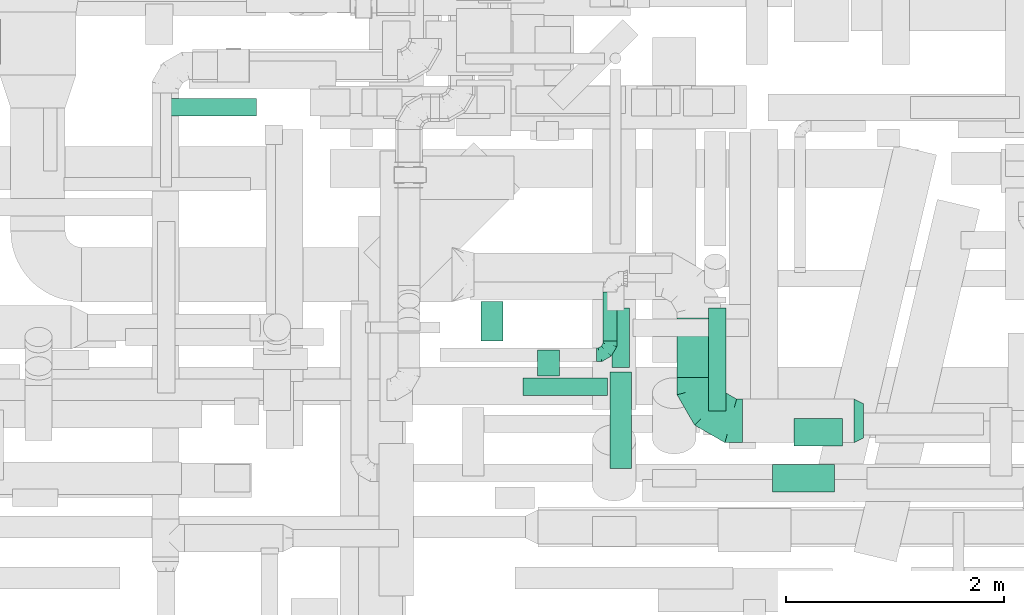
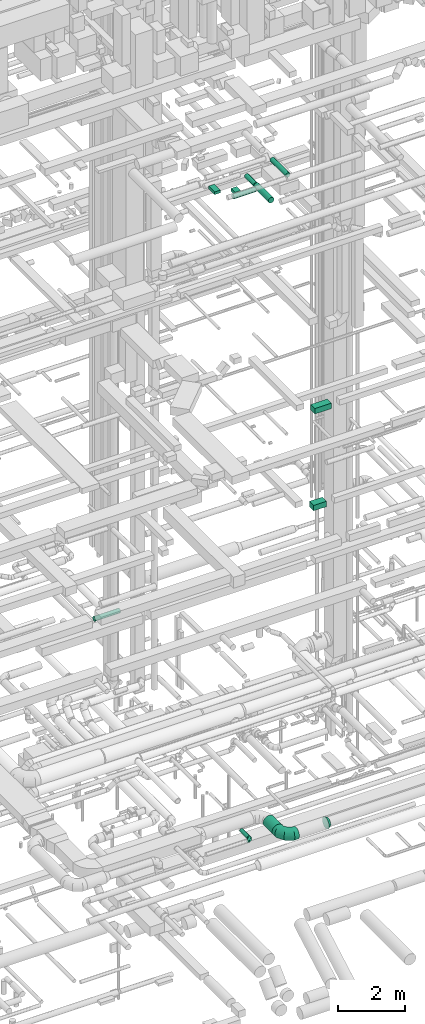
# One storey, part 164 of 337: 11 flow segments, 3 flow fittings.
"""IFC2X3 building model written with IfcOpenShell, lengths in millimetres."""

from ifc_helpers import new_model, entity, si_unit, converted_unit, derived_unit, direction, frame, origin, origin_2d_with_axis, place, context, subcontext, project, spatial, rectangle, circle, extrude, faceted_brep, source, transform, mapped, material, type_object, type_shapes, element, save


model = new_model("IFC2X3")

# Units and contexts
model_context = context("Model", 3, precision=0.01, world=origin(), true_north=direction((6.12303176911189e-17, 1.0)))
body_context = subcontext(model_context, "Body", "Model", "MODEL_VIEW")
ifc_project = project(units=[si_unit("LENGTHUNIT", "METRE", prefix="MILLI"), si_unit("AREAUNIT", "SQUARE_METRE"), si_unit("VOLUMEUNIT", "CUBIC_METRE"), converted_unit("PLANEANGLEUNIT", "DEGREE", entity("IfcRatioMeasure", 0.0174532925199433), si_unit("PLANEANGLEUNIT", "RADIAN"), dimensions=[0, 0, 0, 0, 0, 0, 0]), si_unit("MASSUNIT", "GRAM", prefix="KILO"), derived_unit("MASSDENSITYUNIT", [(si_unit("MASSUNIT", "GRAM", prefix="KILO"), 1), (si_unit("LENGTHUNIT", "METRE"), -3)]), derived_unit("MOMENTOFINERTIAUNIT", [(si_unit("LENGTHUNIT", "METRE"), 4)]), si_unit("TIMEUNIT", "SECOND"), si_unit("FREQUENCYUNIT", "HERTZ"), si_unit("THERMODYNAMICTEMPERATUREUNIT", "DEGREE_CELSIUS"), derived_unit("THERMALTRANSMITTANCEUNIT", [(si_unit("MASSUNIT", "GRAM", prefix="KILO"), 1), (si_unit("THERMODYNAMICTEMPERATUREUNIT", "KELVIN"), -1), (si_unit("TIMEUNIT", "SECOND"), -3)]), derived_unit("VOLUMETRICFLOWRATEUNIT", [(si_unit("LENGTHUNIT", "METRE"), 3), (si_unit("TIMEUNIT", "SECOND"), -1)]), derived_unit("MASSFLOWRATEUNIT", [(si_unit("MASSUNIT", "GRAM", prefix="KILO"), 1), (si_unit("TIMEUNIT", "SECOND"), -1)]), derived_unit("ROTATIONALFREQUENCYUNIT", [(si_unit("TIMEUNIT", "SECOND"), -1)]), si_unit("ELECTRICCURRENTUNIT", "AMPERE"), si_unit("ELECTRICVOLTAGEUNIT", "VOLT"), si_unit("POWERUNIT", "WATT"), si_unit("FORCEUNIT", "NEWTON", prefix="KILO"), si_unit("ILLUMINANCEUNIT", "LUX"), si_unit("LUMINOUSFLUXUNIT", "LUMEN"), si_unit("LUMINOUSINTENSITYUNIT", "CANDELA"), derived_unit("USERDEFINED", [(si_unit("MASSUNIT", "GRAM", prefix="KILO"), -1), (si_unit("LENGTHUNIT", "METRE"), -2), (si_unit("TIMEUNIT", "SECOND"), 3), (si_unit("LUMINOUSFLUXUNIT", "LUMEN"), 1)]), derived_unit("LINEARVELOCITYUNIT", [(si_unit("LENGTHUNIT", "METRE"), 1), (si_unit("TIMEUNIT", "SECOND"), -1)]), si_unit("PRESSUREUNIT", "PASCAL"), derived_unit("USERDEFINED", [(si_unit("LENGTHUNIT", "METRE"), -2), (si_unit("MASSUNIT", "GRAM", prefix="KILO"), 1), (si_unit("TIMEUNIT", "SECOND"), -2)]), derived_unit("LINEARFORCEUNIT", [(si_unit("MASSUNIT", "GRAM", prefix="KILO"), 1), (si_unit("LENGTHUNIT", "METRE"), 1), (si_unit("TIMEUNIT", "SECOND"), -2), (si_unit("LENGTHUNIT", "METRE"), -1)]), derived_unit("PLANARFORCEUNIT", [(si_unit("MASSUNIT", "GRAM", prefix="KILO"), 1), (si_unit("LENGTHUNIT", "METRE"), 1), (si_unit("TIMEUNIT", "SECOND"), -2), (si_unit("LENGTHUNIT", "METRE"), -2)])], contexts=[model_context])

# Site, building, storey
site_placement = place(None, origin())
site = spatial("IfcSite", under=ifc_project, at=site_placement, CompositionType="ELEMENT")
building_placement = place(site_placement, origin())
building = spatial("IfcBuilding", under=site, at=building_placement, CompositionType="ELEMENT")
storey_placement = place(building_placement, origin())
storey = spatial("IfcBuildingStorey", under=building, at=storey_placement, CompositionType="ELEMENT", Elevation=0.0)

# Flow segments
duct_segment_type_1 = type_object("IfcDuctSegmentType", PredefinedType="NOTDEFINED")
flow_segment_1_placement = place(storey_placement, frame((52915.22, 2152.06, 19075.0)))
element("IfcFlowSegment", 1, at=flow_segment_1_placement, inside=storey, type_object=duct_segment_type_1, context=body_context, shape_type="SweptSolid", body=[
    extrude(rectangle(XDim=570.000000000061, YDim=250.0, at=origin_2d_with_axis()), frame((285.0, 125.0, 0.0)), (0.0, 0.0, 1.0), 200.000000000002),
])
flow_segment_2_placement = place(storey_placement, frame((53116.01, 2575.44, 15200.0)))
element("IfcFlowSegment", 2, at=flow_segment_2_placement, inside=storey, type_object=duct_segment_type_1, context=body_context, shape_type="SweptSolid", body=[
    extrude(rectangle(XDim=445.00000000002, YDim=250.0, at=origin_2d_with_axis()), frame((222.5, 125.0, 0.0)), (0.0, 0.0, 1.0), 200.000000000002),
])
flow_segment_3_placement = place(storey_placement, frame((50242.89, 3538.11, 27200.0)))
element("IfcFlowSegment", 3, at=flow_segment_3_placement, inside=storey, type_object=duct_segment_type_1, context=body_context, shape_type="SweptSolid", body=[
    extrude(rectangle(XDim=360.627460668063, YDim=199.999999999998, at=origin_2d_with_axis()), frame((100.0, 180.31, 0.0), z_axis=(0.0, 0.0, 1.0), x_axis=(0.0, -1.0, 0.0)), (0.0, 0.0, 1.0), 100.000000000003),
])
flow_segment_4_placement = place(storey_placement, frame((50760.52, 3214.9, 27200.0)))
element("IfcFlowSegment", 4, at=flow_segment_4_placement, inside=storey, type_object=duct_segment_type_1, context=body_context, shape_type="SweptSolid", body=[
    extrude(rectangle(XDim=239.999999999976, YDim=199.999999999998, at=origin_2d_with_axis()), frame((100.0, 120.0, 0.0), z_axis=(0.0, 0.0, 1.0), x_axis=(0.0, 1.0, 0.0)), (0.0, 0.0, 1.0), 100.000000000003),
])
duct_segment_type_2 = type_object("IfcDuctSegmentType", PredefinedType="NOTDEFINED")
flow_segment_5_placement = place(storey_placement, frame((47301.3, 5598.95, 11318.4)))
element("IfcFlowSegment", 5, at=flow_segment_5_placement, inside=storey, type_object=duct_segment_type_2, context=body_context, shape_type="SweptSolid", body=[
    extrude(circle(Radius=80.0, at=origin_2d_with_axis()), frame((0.0, 81.6, 81.6), z_axis=(1.0, 0.0, 0.0), x_axis=(0.0, 1.0, 0.0)), (0.0, 0.0, 1.0), 880.000000000025),
])
flow_segment_6_placement = place(storey_placement, frame((52039.25, 3203.74, 3248.4)))
element("IfcFlowSegment", 6, at=flow_segment_6_placement, inside=storey, type_object=duct_segment_type_2, context=body_context, shape_type="SweptSolid", body=[
    extrude(circle(Radius=200.0, at=origin_2d_with_axis()), frame((201.6, 0.0, 201.6), z_axis=(0.0, 1.0, 0.0), x_axis=(-1.0, 0.0, 0.0)), (0.0, 0.0, 1.0), 542.500000000014),
])
flow_segment_7_placement = place(storey_placement, frame((52328.05, 2895.97, 27468.4)))
element("IfcFlowSegment", 7, at=flow_segment_7_placement, inside=storey, type_object=duct_segment_type_2, context=body_context, shape_type="SweptSolid", body=[
    extrude(circle(Radius=80.0, at=origin_2d_with_axis()), frame((81.6, 0.0, 81.6), z_axis=(0.0, 1.0, 0.0), x_axis=(-1.0, 0.0, 0.0)), (0.0, 0.0, 1.0), 942.141311520767),
])
flow_segment_8_placement = place(storey_placement, frame((51422.09, 2365.61, 27158.4)))
element("IfcFlowSegment", 8, at=flow_segment_8_placement, inside=storey, type_object=duct_segment_type_2, context=body_context, shape_type="SweptSolid", body=[
    extrude(circle(Radius=100.0, at=origin_2d_with_axis()), frame((101.6, 0.0, 101.6), z_axis=(0.0, 1.0, 0.0), x_axis=(1.0, 0.0, 0.0)), (0.0, 0.0, 1.0), 887.500000000023),
])
flow_segment_9_placement = place(storey_placement, frame((51442.09, 3293.11, 27178.4)))
element("IfcFlowSegment", 9, at=flow_segment_9_placement, inside=storey, type_object=duct_segment_type_2, context=body_context, shape_type="SweptSolid", body=[
    extrude(circle(Radius=80.0, at=origin_2d_with_axis()), frame((81.6, 0.0, 81.6), z_axis=(0.0, 1.0, 0.0), x_axis=(1.0, 0.0, 0.0)), (0.0, 0.0, 1.0), 544.999999999997),
])
flow_segment_10_placement = place(storey_placement, frame((50628.69, 3033.31, 27168.4)))
element("IfcFlowSegment", 10, at=flow_segment_10_placement, inside=storey, type_object=duct_segment_type_2, context=body_context, shape_type="SweptSolid", body=[
    extrude(circle(Radius=80.0, at=origin_2d_with_axis()), frame((0.0, 81.6, 81.6), z_axis=(1.0, 0.0, 0.0), x_axis=(0.0, 1.0, 0.0)), (0.0, 0.0, 1.0), 775.501256289328),
])
flow_segment_11_placement = place(storey_placement, frame((51360.9, 3535.29, 3185.9)))
element("IfcFlowSegment", 11, at=flow_segment_11_placement, inside=storey, type_object=duct_segment_type_2, context=body_context, shape_type="SweptSolid", body=[
    extrude(circle(Radius=62.5, at=origin_2d_with_axis()), frame((64.1, 0.0, 64.1), z_axis=(0.0, 1.0, 0.0), x_axis=(-1.0, 0.0, 0.0)), (0.0, 0.0, 1.0), 450.000000000008),
])

# Flow fittings
ifc_material = material()
duct_fitting_type_1 = type_object("IfcDuctFittingType", PredefinedType="NOTDEFINED", material=ifc_material)
shared_shape_1 = source(origin(), body_context, "Body", "Brep", [
    faceted_brep([(-125.0, 0.0, -62.5), (-125.0, -16.18, -60.37), (-125.0, -31.25, -54.13), (-125.0, -44.19, -44.19), (-125.0, -54.13, -31.25), (-125.0, -60.37, -16.18), (-125.0, -62.5, 0.0), (-125.0, -60.37, 16.18), (-125.0, -54.13, 31.25), (-125.0, -44.19, 44.19), (-125.0, -31.25, 54.13), (-125.0, -16.18, 60.37), (-125.0, 0.0, 62.5), (-125.0, 16.18, 60.37), (-125.0, 31.25, 54.13), (-125.0, 44.19, 44.19), (-125.0, 54.13, 31.25), (-125.0, 60.37, 16.18), (-125.0, 62.5, 0.0), (-125.0, 60.37, -16.18), (-125.0, 54.13, -31.25), (-125.0, 44.19, -44.19), (-125.0, 31.25, -54.13), (-125.0, 16.18, -60.37), (-95.84, 16.18, 60.37), (-99.88, 31.25, 54.13), (-91.51, 0.0, 62.5), (-103.35, 44.19, 44.19), (-107.68, 60.37, 16.18), (-108.25, 62.5, 0.0), (-106.01, 54.13, 31.25), (-106.01, 54.13, -31.25), (-103.35, 44.19, -44.19), (-107.68, 60.37, -16.18), (-95.84, 16.18, -60.37), (-91.51, 0.0, -62.5), (-99.88, 31.25, -54.13), (-87.17, -16.18, -60.37), (-83.13, -31.25, -54.13), (-79.66, -44.19, -44.19), (-77.0, -54.13, -31.25), (-75.33, -60.37, -16.18), (-74.76, -62.5, 0.0), (-75.33, -60.37, 16.18), (-77.0, -54.13, 31.25), (-79.66, -44.19, 44.19), (-83.13, -31.25, 54.13), (-87.17, -16.18, 60.37), (-45.34, 45.34, 60.37), (-56.37, 56.37, 54.13), (-33.49, 33.49, 62.5), (-65.85, 65.85, 44.19), (-73.12, 73.12, 31.25), (-77.69, 77.69, 16.18), (-79.25, 79.25, 0.0), (-77.69, 77.69, -16.18), (-73.12, 73.12, -31.25), (-65.85, 65.85, -44.19), (-45.34, 45.34, -60.37), (-33.49, 33.49, -62.5), (-56.37, 56.37, -54.13), (-21.65, 21.65, -60.37), (-10.62, 10.62, -54.13), (-1.14, 1.14, -44.19), (6.13, -6.13, -31.25), (10.7, -10.7, -16.18), (12.26, -12.26, 0.0), (10.7, -10.7, 16.18), (6.13, -6.13, 31.25), (-1.14, 1.14, 44.19), (-10.62, 10.62, 54.13), (-21.65, 21.65, 60.37), (-16.18, 95.84, 60.37), (-31.25, 99.88, 54.13), (0.0, 91.51, 62.5), (-44.19, 103.35, 44.19), (-54.13, 106.01, 31.25), (-60.37, 107.68, 16.18), (-62.5, 108.25, 0.0), (-60.37, 107.68, -16.18), (-54.13, 106.01, -31.25), (-44.19, 103.35, -44.19), (-16.18, 95.84, -60.37), (0.0, 91.51, -62.5), (-31.25, 99.88, -54.13), (16.18, 87.17, -60.37), (31.25, 83.13, -54.13), (44.19, 79.66, -44.19), (54.13, 77.0, -31.25), (60.37, 75.33, -16.18), (62.5, 74.76, 0.0), (60.37, 75.33, 16.18), (54.13, 77.0, 31.25), (44.19, 79.66, 44.19), (31.25, 83.13, 54.13), (16.18, 87.17, 60.37), (-16.18, 125.0, -60.37), (-31.25, 125.0, -54.13), (-44.19, 125.0, -44.19), (-54.13, 125.0, -31.25), (-60.37, 125.0, -16.18), (-62.5, 125.0, 0.0), (-60.37, 125.0, 16.18), (-54.13, 125.0, 31.25), (-44.19, 125.0, 44.19), (-31.25, 125.0, 54.13), (-16.18, 125.0, 60.37), (0.0, 125.0, 62.5), (16.18, 125.0, 60.37), (31.25, 125.0, 54.13), (44.19, 125.0, 44.19), (54.13, 125.0, 31.25), (60.37, 125.0, 16.18), (62.5, 125.0, 0.0), (60.37, 125.0, -16.18), (54.13, 125.0, -31.25), (44.19, 125.0, -44.19), (31.25, 125.0, -54.13), (16.18, 125.0, -60.37), (0.0, 125.0, -62.5)], [[[0, 1, 2, 3, 4, 5, 6, 7, 8, 9, 10, 11, 12, 13, 14, 15, 16, 17, 18, 19, 20, 21, 22, 23]], [[24, 25, 14, 13]], [[26, 24, 13, 12]], [[14, 25, 27, 15]], [[28, 29, 18, 17]], [[30, 28, 17, 16]], [[15, 27, 30, 16]], [[20, 31, 32, 21]], [[33, 31, 20, 19]], [[18, 29, 33, 19]], [[34, 35, 0, 23]], [[36, 34, 23, 22]], [[21, 32, 36, 22]], [[1, 0, 35, 37]], [[2, 1, 37, 38]], [[38, 39, 3, 2]], [[5, 4, 40, 41]], [[6, 5, 41, 42]], [[39, 40, 4, 3]], [[6, 42, 43, 7]], [[7, 43, 44, 8]], [[45, 9, 8, 44]], [[9, 45, 46, 10]], [[10, 46, 47, 11]], [[26, 12, 11, 47]], [[48, 49, 25, 24]], [[50, 48, 24, 26]], [[27, 25, 49, 51]], [[52, 53, 28, 30]], [[51, 52, 30, 27]], [[29, 28, 53, 54]], [[55, 56, 31, 33]], [[54, 55, 33, 29]], [[57, 32, 31, 56]], [[58, 59, 35, 34]], [[60, 58, 34, 36]], [[57, 60, 36, 32]], [[37, 35, 59, 61]], [[38, 37, 61, 62]], [[39, 38, 62, 63]], [[41, 40, 64, 65]], [[42, 41, 65, 66]], [[63, 64, 40, 39]], [[43, 42, 66, 67]], [[44, 43, 67, 68]], [[68, 69, 45, 44]], [[46, 45, 69, 70]], [[47, 46, 70, 71]], [[26, 47, 71, 50]], [[72, 73, 49, 48]], [[74, 72, 48, 50]], [[51, 49, 73, 75]], [[76, 77, 53, 52]], [[75, 76, 52, 51]], [[54, 53, 77, 78]], [[79, 80, 56, 55]], [[78, 79, 55, 54]], [[81, 57, 56, 80]], [[82, 83, 59, 58]], [[84, 82, 58, 60]], [[81, 84, 60, 57]], [[61, 59, 83, 85]], [[62, 61, 85, 86]], [[63, 62, 86, 87]], [[65, 64, 88, 89]], [[66, 65, 89, 90]], [[87, 88, 64, 63]], [[67, 66, 90, 91]], [[68, 67, 91, 92]], [[92, 93, 69, 68]], [[70, 69, 93, 94]], [[71, 70, 94, 95]], [[50, 71, 95, 74]], [[96, 97, 98, 99, 100, 101, 102, 103, 104, 105, 106, 107, 108, 109, 110, 111, 112, 113, 114, 115, 116, 117, 118, 119]], [[72, 74, 107, 106]], [[73, 72, 106, 105]], [[75, 73, 105, 104]], [[77, 76, 103, 102]], [[78, 77, 102, 101]], [[75, 104, 103, 76]], [[78, 101, 100, 79]], [[79, 100, 99, 80]], [[80, 99, 98, 81]], [[96, 119, 83, 82]], [[97, 96, 82, 84]], [[84, 81, 98, 97]], [[83, 119, 118, 85]], [[85, 118, 117, 86]], [[116, 87, 86, 117]], [[88, 115, 114, 89]], [[89, 114, 113, 90]], [[115, 88, 87, 116]], [[91, 90, 113, 112]], [[92, 91, 112, 111]], [[111, 110, 93, 92]], [[95, 94, 109, 108]], [[74, 95, 108, 107]], [[110, 109, 94, 93]]]),
])
type_shapes(duct_fitting_type_1, [shared_shape_1])
flow_fitting_1_placement = place(storey_placement, frame((51425.0, 3410.29, 3250.0)))
element("IfcFlowFitting", 12, at=flow_fitting_1_placement, inside=storey, type_object=duct_fitting_type_1, material=ifc_material, context=body_context, shape_type="MappedRepresentation", body=[
    mapped(shared_shape_1, transform((0.0, 0.0, 0.0), scale=1.0)),
])
duct_fitting_type_2 = type_object("IfcDuctFittingType", PredefinedType="NOTDEFINED", material=ifc_material)
shared_shape_2 = source(origin(), body_context, "Body", "Brep", [
    faceted_brep([(-400.0, 0.0, -200.0), (-400.0, -44.5, -194.99), (-400.0, -86.78, -180.19), (-400.0, -124.7, -156.37), (-400.0, -156.37, -124.7), (-400.0, -180.19, -86.78), (-400.0, -194.99, -44.5), (-400.0, -200.0, 0.0), (-400.0, -194.99, 44.5), (-400.0, -180.19, 86.78), (-400.0, -156.37, 124.7), (-400.0, -124.7, 156.37), (-400.0, -86.78, 180.19), (-400.0, -44.5, 194.99), (-400.0, 0.0, 200.0), (-400.0, 44.5, 194.99), (-400.0, 86.78, 180.19), (-400.0, 124.7, 156.37), (-400.0, 156.37, 124.7), (-400.0, 180.19, 86.78), (-400.0, 194.99, 44.5), (-400.0, 200.0, 0.0), (-400.0, 194.99, -44.5), (-400.0, 180.19, -86.78), (-400.0, 156.37, -124.7), (-400.0, 124.7, -156.37), (-400.0, 86.78, -180.19), (-400.0, 44.5, -194.99), (-292.82, 0.0, 200.0), (-304.75, 44.5, 194.99), (-316.07, 86.78, 180.19), (-326.23, 124.7, 156.37), (-334.72, 156.37, 124.7), (-341.1, 180.19, 86.78), (-345.07, 194.99, 44.5), (-346.41, 200.0, 0.0), (-345.07, 194.99, -44.5), (-341.1, 180.19, -86.78), (-334.72, 156.37, -124.7), (-326.23, 124.7, -156.37), (-316.07, 86.78, -180.19), (-304.75, 44.5, -194.99), (-292.82, 0.0, -200.0), (-280.9, -44.5, -194.99), (-269.57, -86.78, -180.19), (-259.41, -124.7, -156.37), (-250.92, -156.37, -124.7), (-244.54, -180.19, -86.78), (-240.57, -194.99, -44.5), (-239.23, -200.0, 0.0), (-240.57, -194.99, 44.5), (-244.54, -180.19, 86.78), (-250.92, -156.37, 124.7), (-259.41, -124.7, 156.37), (-269.57, -86.78, 180.19), (-280.9, -44.5, 194.99), (-107.18, 107.18, 200.0), (-139.76, 139.76, 194.99), (-170.7, 170.7, 180.19), (-198.46, 198.46, 156.37), (-221.65, 221.65, 124.7), (-239.09, 239.09, 86.78), (-249.92, 249.92, 44.5), (-253.59, 253.59, 0.0), (-249.92, 249.92, -44.5), (-239.09, 239.09, -86.78), (-221.65, 221.65, -124.7), (-198.46, 198.46, -156.37), (-170.7, 170.7, -180.19), (-139.76, 139.76, -194.99), (-107.18, 107.18, -200.0), (-74.6, 74.6, -194.99), (-43.65, 43.65, -180.19), (-15.89, 15.89, -156.37), (7.29, -7.29, -124.7), (24.73, -24.73, -86.78), (35.56, -35.56, -44.5), (39.23, -39.23, 0.0), (35.56, -35.56, 44.5), (24.73, -24.73, 86.78), (7.29, -7.29, 124.7), (-15.89, 15.89, 156.37), (-43.65, 43.65, 180.19), (-74.6, 74.6, 194.99), (0.0, 292.82, 200.0), (-44.5, 304.75, 194.99), (-86.78, 316.07, 180.19), (-124.7, 326.23, 156.37), (-156.37, 334.72, 124.7), (-180.19, 341.1, 86.78), (-194.99, 345.07, 44.5), (-200.0, 346.41, 0.0), (-194.99, 345.07, -44.5), (-180.19, 341.1, -86.78), (-156.37, 334.72, -124.7), (-124.7, 326.23, -156.37), (-86.78, 316.07, -180.19), (-44.5, 304.75, -194.99), (0.0, 292.82, -200.0), (44.5, 280.9, -194.99), (86.78, 269.57, -180.19), (124.7, 259.41, -156.37), (156.37, 250.92, -124.7), (180.19, 244.54, -86.78), (194.99, 240.57, -44.5), (200.0, 239.23, 0.0), (194.99, 240.57, 44.5), (180.19, 244.54, 86.78), (156.37, 250.92, 124.7), (124.7, 259.41, 156.37), (86.78, 269.57, 180.19), (44.5, 280.9, 194.99), (-44.5, 400.0, -194.99), (-86.78, 400.0, -180.19), (-124.7, 400.0, -156.37), (-156.37, 400.0, -124.7), (-180.19, 400.0, -86.78), (-194.99, 400.0, -44.5), (-200.0, 400.0, 0.0), (-194.99, 400.0, 44.5), (-180.19, 400.0, 86.78), (-156.37, 400.0, 124.7), (-124.7, 400.0, 156.37), (-86.78, 400.0, 180.19), (-44.5, 400.0, 194.99), (0.0, 400.0, 200.0), (44.5, 400.0, 194.99), (86.78, 400.0, 180.19), (124.7, 400.0, 156.37), (156.37, 400.0, 124.7), (180.19, 400.0, 86.78), (194.99, 400.0, 44.5), (200.0, 400.0, 0.0), (194.99, 400.0, -44.5), (180.19, 400.0, -86.78), (156.37, 400.0, -124.7), (124.7, 400.0, -156.37), (86.78, 400.0, -180.19), (44.5, 400.0, -194.99), (0.0, 400.0, -200.0)], [[[0, 1, 2, 3, 4, 5, 6, 7, 8, 9, 10, 11, 12, 13, 14, 15, 16, 17, 18, 19, 20, 21, 22, 23, 24, 25, 26, 27]], [[28, 29, 15, 14]], [[30, 31, 17, 16]], [[29, 30, 16, 15]], [[31, 32, 18, 17]], [[32, 33, 19, 18]], [[34, 35, 21, 20]], [[33, 34, 20, 19]], [[35, 36, 22, 21]], [[37, 38, 24, 23]], [[36, 37, 23, 22]], [[38, 39, 25, 24]], [[39, 40, 26, 25]], [[41, 42, 0, 27]], [[40, 41, 27, 26]], [[1, 0, 42, 43]], [[43, 44, 2, 1]], [[45, 3, 2, 44]], [[45, 46, 4, 3]], [[5, 4, 46, 47]], [[47, 48, 6, 5]], [[49, 7, 6, 48]], [[7, 49, 50, 8]], [[8, 50, 51, 9]], [[9, 51, 52, 10]], [[52, 53, 11, 10]], [[11, 53, 54, 12]], [[12, 54, 55, 13]], [[13, 55, 28, 14]], [[56, 57, 29, 28]], [[58, 59, 31, 30]], [[57, 58, 30, 29]], [[59, 60, 32, 31]], [[60, 61, 33, 32]], [[62, 63, 35, 34]], [[61, 62, 34, 33]], [[63, 64, 36, 35]], [[65, 66, 38, 37]], [[64, 65, 37, 36]], [[66, 67, 39, 38]], [[67, 68, 40, 39]], [[69, 70, 42, 41]], [[68, 69, 41, 40]], [[43, 42, 70, 71]], [[71, 72, 44, 43]], [[73, 45, 44, 72]], [[73, 74, 46, 45]], [[47, 46, 74, 75]], [[75, 76, 48, 47]], [[77, 49, 48, 76]], [[50, 49, 77, 78]], [[51, 50, 78, 79]], [[52, 51, 79, 80]], [[80, 81, 53, 52]], [[54, 53, 81, 82]], [[55, 54, 82, 83]], [[28, 55, 83, 56]], [[84, 85, 57, 56]], [[86, 87, 59, 58]], [[85, 86, 58, 57]], [[87, 88, 60, 59]], [[88, 89, 61, 60]], [[90, 91, 63, 62]], [[89, 90, 62, 61]], [[91, 92, 64, 63]], [[93, 94, 66, 65]], [[92, 93, 65, 64]], [[94, 95, 67, 66]], [[95, 96, 68, 67]], [[97, 98, 70, 69]], [[96, 97, 69, 68]], [[71, 70, 98, 99]], [[99, 100, 72, 71]], [[101, 73, 72, 100]], [[101, 102, 74, 73]], [[75, 74, 102, 103]], [[103, 104, 76, 75]], [[105, 77, 76, 104]], [[78, 77, 105, 106]], [[79, 78, 106, 107]], [[80, 79, 107, 108]], [[108, 109, 81, 80]], [[82, 81, 109, 110]], [[83, 82, 110, 111]], [[56, 83, 111, 84]], [[112, 113, 114, 115, 116, 117, 118, 119, 120, 121, 122, 123, 124, 125, 126, 127, 128, 129, 130, 131, 132, 133, 134, 135, 136, 137, 138, 139]], [[85, 84, 125, 124]], [[86, 85, 124, 123]], [[87, 86, 123, 122]], [[122, 121, 88, 87]], [[89, 88, 121, 120]], [[90, 89, 120, 119]], [[91, 90, 119, 118]], [[91, 118, 117, 92]], [[92, 117, 116, 93]], [[93, 116, 115, 94]], [[115, 114, 95, 94]], [[95, 114, 113, 96]], [[96, 113, 112, 97]], [[97, 112, 139, 98]], [[98, 139, 138, 99]], [[99, 138, 137, 100]], [[100, 137, 136, 101]], [[136, 135, 102, 101]], [[102, 135, 134, 103]], [[103, 134, 133, 104]], [[104, 133, 132, 105]], [[106, 105, 132, 131]], [[107, 106, 131, 130]], [[108, 107, 130, 129]], [[129, 128, 109, 108]], [[110, 109, 128, 127]], [[111, 110, 127, 126]], [[84, 111, 126, 125]]]),
])
type_shapes(duct_fitting_type_2, [shared_shape_2])
flow_fitting_2_placement = place(storey_placement, frame((52240.84, 2803.74, 3450.0), z_axis=(0.0, 0.0, 1.0), x_axis=(0.0, -1.0, 0.0)))
element("IfcFlowFitting", 13, at=flow_fitting_2_placement, inside=storey, type_object=duct_fitting_type_2, material=ifc_material, context=body_context, shape_type="MappedRepresentation", body=[
    mapped(shared_shape_2, transform((0.0, 0.0, 0.0), scale=1.0)),
])
duct_fitting_type_3 = type_object("IfcDuctFittingType", PredefinedType="NOTDEFINED", material=ifc_material)
shared_shape_3 = source(origin(), body_context, "Body", "Brep", [
    faceted_brep([(85.0, 111.37, -111.37), (85.0, 136.4, -78.75), (85.0, 152.13, -40.76), (85.0, 157.5, 0.0), (85.0, 152.13, 40.76), (85.0, 136.4, 78.75), (85.0, 111.37, 111.37), (85.0, 78.75, 136.4), (85.0, 40.76, 152.13), (85.0, 0.0, 157.5), (85.0, -40.76, 152.13), (85.0, -78.75, 136.4), (85.0, -111.37, 111.37), (85.0, -136.4, 78.75), (85.0, -152.13, 40.76), (85.0, -157.5, 0.0), (85.0, -152.13, -40.76), (85.0, -136.4, -78.75), (85.0, -111.37, -111.37), (85.0, -78.75, -136.4), (85.0, -40.76, -152.13), (85.0, 0.0, -157.5), (85.0, 40.76, -152.13), (85.0, 78.75, -136.4), (0.0, -200.0, 0.0), (0.0, -194.99, 44.5), (0.0, -180.19, 86.78), (0.0, -156.37, 124.7), (0.0, -124.7, 156.37), (0.0, -86.78, 180.19), (0.0, -44.5, 194.99), (0.0, 0.0, 200.0), (0.0, 44.5, 194.99), (0.0, 86.78, 180.19), (0.0, 124.7, 156.37), (0.0, 156.37, 124.7), (0.0, 180.19, 86.78), (0.0, 194.99, 44.5), (0.0, 200.0, 0.0), (0.0, 194.99, -44.5), (0.0, 180.19, -86.78), (0.0, 156.37, -124.7), (0.0, 124.7, -156.37), (0.0, 86.78, -180.19), (0.0, 44.5, -194.99), (0.0, 0.0, -200.0), (0.0, -44.5, -194.99), (0.0, -86.78, -180.19), (0.0, -124.7, -156.37), (0.0, -156.37, -124.7), (0.0, -180.19, -86.78), (0.0, -194.99, -44.5)], [[[0, 1, 2, 3, 4, 5, 6, 7, 8, 9, 10, 11, 12, 13, 14, 15, 16, 17, 18, 19, 20, 21, 22, 23]], [[24, 25, 26, 27, 28, 29, 30, 31, 32, 33, 34, 35, 36, 37, 38, 39, 40, 41, 42, 43, 44, 45, 46, 47, 48, 49, 50, 51]], [[8, 7, 33]], [[9, 8, 32]], [[31, 9, 32]], [[32, 8, 33]], [[7, 34, 33]], [[7, 6, 34]], [[35, 6, 5]], [[4, 3, 37]], [[36, 5, 4]], [[36, 35, 5]], [[37, 36, 4]], [[3, 38, 37]], [[6, 35, 34]], [[14, 13, 26]], [[15, 14, 25]], [[24, 15, 25]], [[25, 14, 26]], [[13, 27, 26]], [[13, 12, 27]], [[28, 12, 11]], [[10, 9, 30]], [[29, 11, 10]], [[29, 28, 11]], [[30, 29, 10]], [[9, 31, 30]], [[12, 28, 27]], [[20, 19, 47]], [[21, 20, 46]], [[45, 21, 46]], [[46, 20, 47]], [[19, 48, 47]], [[19, 18, 48]], [[49, 18, 17]], [[16, 15, 51]], [[50, 17, 16]], [[50, 49, 17]], [[51, 50, 16]], [[15, 24, 51]], [[18, 49, 48]], [[2, 1, 40]], [[3, 2, 39]], [[38, 3, 39]], [[39, 2, 40]], [[1, 41, 40]], [[1, 0, 41]], [[42, 0, 23]], [[22, 21, 44]], [[43, 23, 22]], [[43, 42, 23]], [[44, 43, 22]], [[21, 45, 44]], [[0, 42, 41]]]),
])
type_shapes(duct_fitting_type_3, [shared_shape_3])
flow_fitting_3_placement = place(storey_placement, frame((53665.84, 2803.74, 3450.0)))
element("IfcFlowFitting", 14, at=flow_fitting_3_placement, inside=storey, type_object=duct_fitting_type_3, material=ifc_material, context=body_context, shape_type="MappedRepresentation", body=[
    mapped(shared_shape_3, transform((0.0, 0.0, 0.0), scale=1.0)),
])

save(model, "model.ifc")
